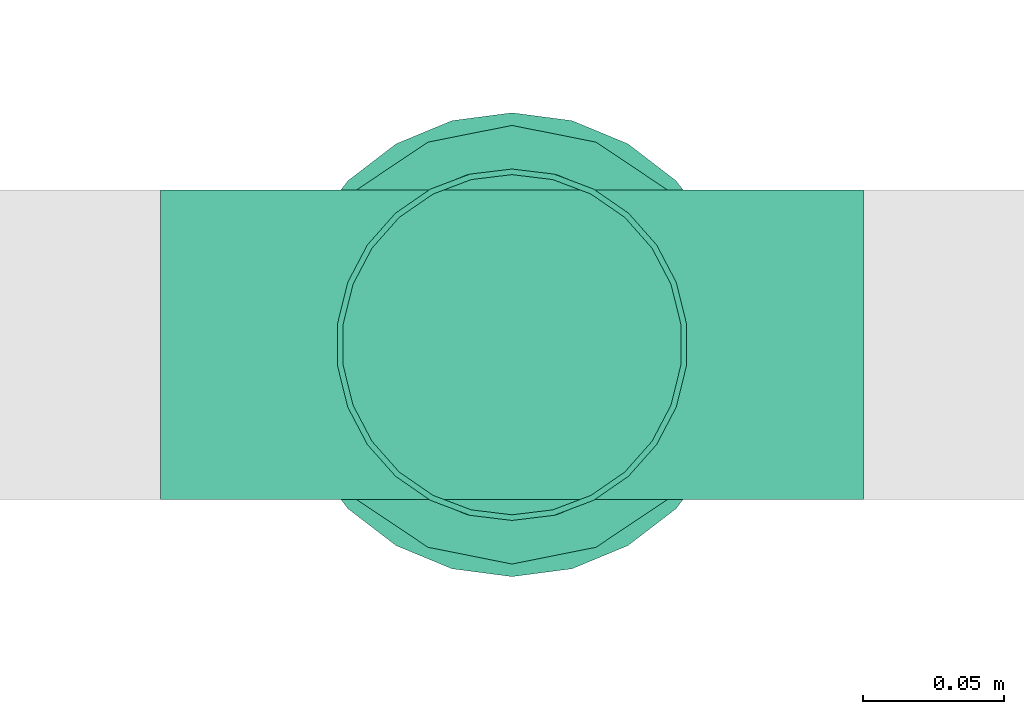
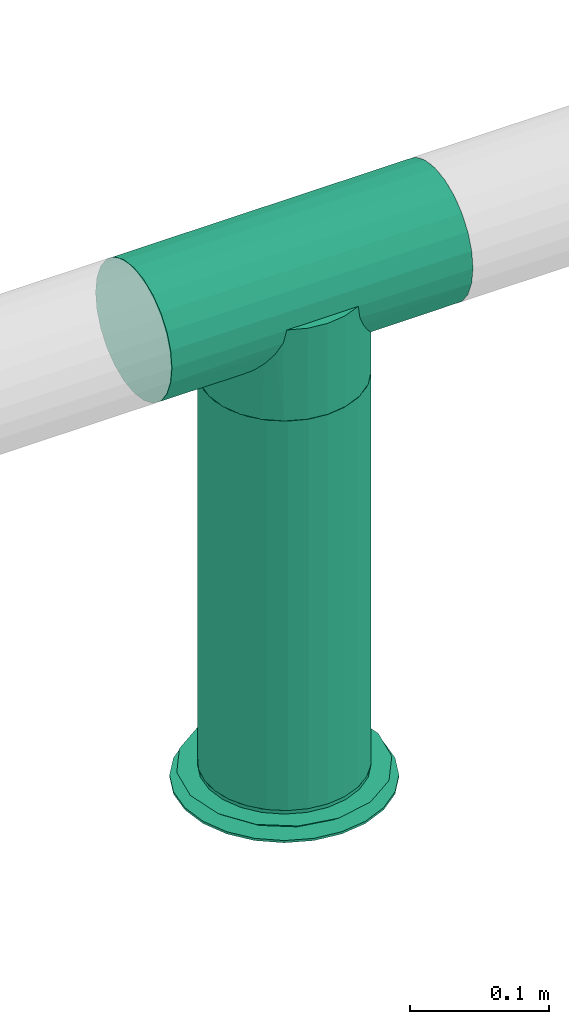
# One storey, part 83 of 123: 1 flow fitting, 1 flow segment, 1 flow terminal.
"""IFC2X3 building model written with IfcOpenShell, lengths in millimetres."""

from ifc_helpers import new_model, entity, si_unit, converted_unit, derived_unit, direction, frame, origin_with_axes, origin_2d_with_axis, place, context, subcontext, project, spatial, hollow_circle, extrude, open_shell, surface_model, source, transform, mapped, material, layer, layer_set, layer_usage, type_object, element, save


model = new_model("IFC2X3")

# Units and contexts
model_context = context("Model", 3, precision=1e-05, world=origin_with_axes(), true_north=direction((0.0, 1.0)))
body_context = subcontext(model_context, "Body", "Model", "MODEL_VIEW")
ifc_project = project(units=[si_unit("AREAUNIT", "SQUARE_METRE"), si_unit("VOLUMEUNIT", "CUBIC_METRE", prefix="DECI"), si_unit("TIMEUNIT", "SECOND"), si_unit("THERMODYNAMICTEMPERATUREUNIT", "DEGREE_CELSIUS"), si_unit("PRESSUREUNIT", "PASCAL"), si_unit("MASSUNIT", "GRAM", prefix="KILO"), si_unit("LENGTHUNIT", "METRE", prefix="MILLI"), si_unit("POWERUNIT", "WATT"), si_unit("ELECTRICCURRENTUNIT", "AMPERE"), si_unit("ELECTRICVOLTAGEUNIT", "VOLT"), derived_unit("VOLUMETRICFLOWRATEUNIT", [(si_unit("VOLUMEUNIT", "CUBIC_METRE", prefix="DECI"), 1), (si_unit("TIMEUNIT", "SECOND"), -1)]), derived_unit("LINEARVELOCITYUNIT", [(si_unit("LENGTHUNIT", "METRE"), 1), (si_unit("TIMEUNIT", "SECOND"), -1)]), derived_unit("MASSDENSITYUNIT", [(si_unit("MASSUNIT", "GRAM", prefix="KILO"), 1), (si_unit("VOLUMEUNIT", "CUBIC_METRE"), -1)]), converted_unit("PLANEANGLEUNIT", "DEGREE", entity("IfcRatioMeasure", 0.01745), si_unit("PLANEANGLEUNIT", "RADIAN"), dimensions=[0, 0, 0, 0, 0, 0, 0])], contexts=[model_context])

# Site, building, storey
site_placement = place(None, origin_with_axes())
site = spatial("IfcSite", under=ifc_project, at=site_placement, CompositionType="ELEMENT")
building_placement = place(site_placement, origin_with_axes())
building = spatial("IfcBuilding", under=site, at=building_placement, Name="mc-building", CompositionType="ELEMENT")
storey_placement = place(building_placement, origin_with_axes())
storey = spatial("IfcBuildingStorey", under=building, at=storey_placement, Name="1. Korrus", CompositionType="ELEMENT", Elevation=0.0)

# Flow terminal
air_terminal_type = type_object("IfcAirTerminalType", Name="125", PredefinedType="NOTDEFINED")
shared_shape_1 = source(origin_with_axes(), body_context, "Body", "SurfaceModel", [
    surface_model("IfcShellBasedSurfaceModel", [(11.2, 41.25, -71.4471), (11.2, 0.0, -82.5), (11.2, 21.35257, -79.68888), (11.2, 71.4471, -41.25), (11.2, 58.33631, -58.33631), (11.2, 79.68888, -21.35257), (11.2, 82.5, 0.0), (11.2, -79.68888, -21.35257), (11.2, -41.25, -71.4471), (11.2, -21.35257, -79.68888), (11.2, -58.33631, -58.33631), (11.2, -71.4471, -41.25), (11.2, 79.68888, 21.35257), (11.2, 71.4471, 41.25), (11.2, 58.33631, 58.33631), (11.2, 41.25, 71.4471), (11.2, 21.35257, 79.68888), (11.2, -58.33631, 58.33631), (11.2, -21.35257, 79.68888), (11.2, 0.0, 82.5), (11.2, -79.68888, 21.35257), (11.2, -71.4471, 41.25), (11.2, -82.5, 0.0), (11.2, -41.25, 71.4471), (9.2, 21.35257, 79.68888), (9.2, -21.35257, 79.68888), (9.2, 0.0, 82.5), (9.2, 58.33631, 58.33631), (9.2, 41.25, 71.4471), (9.2, 71.4471, 41.25), (9.2, 79.68888, 21.35257), (9.2, -58.33631, 58.33631), (9.2, -41.25, 71.4471), (9.2, -79.68888, 21.35257), (9.2, -71.4471, 41.25), (9.2, -58.33631, -58.33631), (9.2, -82.5, 0.0), (9.2, 79.68888, -21.35257), (9.2, 41.25, -71.4471), (9.2, 71.4471, -41.25), (9.2, -41.25, -71.4471), (9.2, 58.33631, -58.33631), (9.2, 0.0, -82.5), (9.2, 21.35257, -79.68888), (9.2, -71.4471, -41.25), (9.2, -79.68888, -21.35257), (9.2, -21.35257, -79.68888), (9.2, 82.5, 0.0), (9.2, 19.5, 33.77499), (9.2, 0.0, 39.0), (9.2, -19.5, 33.77499), (9.2, -39.0, 0.0), (9.2, 33.77499, 19.5), (9.2, 39.0, 0.0), (9.2, -33.77499, 19.5), (9.2, 0.0, -39.0), (9.2, -33.77499, -19.5), (9.2, -19.5, -33.77499), (9.2, 33.77499, -19.5), (9.2, 19.5, -33.77499), (6.2, 25.24133, 18.3389), (6.2, 31.2, 0.0), (6.2, 9.64133, 29.67296), (6.2, -25.24133, 18.3389), (6.2, -9.64133, 29.67296), (6.2, -31.2, 0.0), (6.2, 25.24133, -18.3389), (6.2, 9.64133, -29.67296), (6.2, -9.64133, -29.67296), (6.2, -25.24133, -18.3389), (9.2, 37.1621, -6.85914), (6.2, 28.22067, -9.16945), (9.2, 35.3242, -13.71829), (6.2, -17.44133, -24.00593), (9.2, -26.6375, -26.6375), (6.2, -28.22067, -9.16945), (9.2, -37.1621, -6.85914), (6.2, 17.44133, -24.00593), (9.2, 9.75, -36.3875), (6.2, 0.0, -29.67296), (9.2, -35.3242, -13.71829), (9.2, 26.6375, -26.6375), (9.2, -9.75, -36.3875), (9.2, -37.1621, 6.85914), (6.2, -28.22067, 9.16945), (9.2, -35.3242, 13.71829), (6.2, 17.44133, 24.00593), (9.2, 26.6375, 26.6375), (6.2, 28.22067, 9.16945), (9.2, 37.1621, 6.85914), (6.2, -17.44133, 24.00593), (9.2, -9.75, 36.3875), (6.2, 0.0, 29.67296), (9.2, 35.3242, 13.71829), (9.2, -26.6375, 26.6375), (9.2, 9.75, 36.3875), (6.2, -26.86438, 64.85634), (6.2, -49.63889, 49.63889), (6.2, -64.85634, 26.86438), (6.2, -70.2, 0.0), (6.2, 64.85634, 26.86438), (6.2, 0.0, 70.2), (6.2, 26.86438, 64.85634), (6.2, 49.63889, 49.63889), (6.2, 70.2, 0.0), (6.2, -64.85634, -26.86438), (6.2, -49.63889, -49.63889), (6.2, -26.86438, -64.85634), (6.2, 26.86438, -64.85634), (6.2, 0.0, -70.2), (6.2, 64.85634, -26.86438), (6.2, 49.63889, -49.63889), (0.0, -29.84931, 72.0626), (0.0, 0.0, 78.0), (0.0, 29.84931, 72.0626), (0.0, 55.15433, 55.15433), (0.0, 78.0, 0.0), (0.0, -55.15433, 55.15433), (0.0, -72.0626, 29.84931), (0.0, -78.0, 0.0), (0.0, 72.0626, 29.84931), (0.0, -72.0626, -29.84931), (0.0, 72.0626, -29.84931), (0.0, 55.15433, -55.15433), (0.0, 29.84931, -72.0626), (0.0, -55.15433, -55.15433), (0.0, -29.84931, -72.0626), (0.0, 0.0, -78.0), (6.2, 66.75025, -17.34304), (0.0, 63.60847, -42.50182), (6.2, 57.24762, -38.25164), (0.0, -14.92465, -75.0313), (6.2, -13.43219, -67.52817), (0.0, 42.50182, -63.60847), (6.2, 38.25164, -57.24762), (0.0, 75.0313, -14.92465), (0.0, 14.92465, -75.0313), (6.2, 13.43219, -67.52817), (0.0, -74.16695, -19.27005), (6.2, -67.52817, -13.43219), (0.0, -42.50182, -63.60847), (6.2, -38.25164, -57.24762), (0.0, -63.60847, -42.50182), (6.2, -57.24762, -38.25164), (6.2, -66.75025, 17.34304), (0.0, -63.60847, 42.50182), (6.2, -57.24762, 38.25164), (0.0, 14.92465, 75.0313), (6.2, 13.43219, 67.52817), (0.0, -42.50182, 63.60847), (6.2, -38.25164, 57.24762), (0.0, -75.0313, 14.92465), (0.0, -14.92465, 75.0313), (6.2, -13.43219, 67.52817), (0.0, 74.16695, 19.27005), (6.2, 67.52817, 13.43219), (0.0, 42.50182, 63.60847), (6.2, 38.25164, 57.24762), (0.0, 63.60847, 42.50182), (6.2, 57.24762, 38.25164), (-3.1, 16.17619, 60.37037), (-3.1, -31.25, 54.12659), (-3.1, 0.0, 62.5), (-3.1, 54.12659, 31.25), (-3.1, 31.25, 54.12659), (-3.1, 44.19417, 44.19417), (-3.1, -54.12659, -31.25), (-3.1, -54.12659, 31.25), (-3.1, -44.19417, 44.19417), (-3.1, -16.17619, 60.37037), (-3.1, -62.5, 0.0), (-3.1, -60.37037, 16.17619), (-3.1, 60.37037, 16.17619), (-3.1, 62.5, 0.0), (-3.1, 60.37037, -16.17619), (-3.1, 54.12659, -31.25), (-3.1, 44.19417, -44.19417), (-3.1, 31.25, -54.12659), (-3.1, 16.17619, -60.37037), (-3.1, -31.25, -54.12659), (-3.1, -44.19417, -44.19417), (-3.1, -60.37037, -16.17619), (-3.1, 0.0, -62.5), (-3.1, -16.17619, -60.37037), (0.0, 31.25, -54.12659), (0.0, -54.12659, -31.25), (0.0, 16.17619, -60.37037), (0.0, 54.12659, -31.25), (0.0, 44.19417, -44.19417), (0.0, 60.37037, -16.17619), (0.0, 62.5, 0.0), (0.0, 54.12659, 31.25), (0.0, 16.17619, 60.37037), (0.0, 0.0, -62.5), (0.0, -31.25, -54.12659), (0.0, -16.17619, -60.37037), (0.0, -44.19417, -44.19417), (0.0, -62.5, 0.0), (0.0, -60.37037, -16.17619), (0.0, 44.19417, 44.19417), (0.0, -54.12659, 31.25), (0.0, 31.25, 54.12659), (0.0, 0.0, 62.5), (0.0, -60.37037, 16.17619), (0.0, -31.25, 54.12659), (0.0, -44.19417, 44.19417), (0.0, -16.17619, 60.37037), (0.0, 60.37037, 16.17619), (-43.1, -14.75269, 55.05777), (-43.1, 0.0, 57.0), (-43.1, 14.75269, 55.05777), (-43.1, 28.5, 49.36345), (-43.1, 40.30508, 40.30508), (-43.1, 49.36345, 28.5), (-43.1, 55.05777, 14.75269), (-43.1, -28.5, 49.36345), (-43.1, -49.36345, 28.5), (-43.1, -40.30508, 40.30508), (-43.1, -57.0, 0.0), (-43.1, -55.05777, 14.75269), (-43.1, -40.30508, -40.30508), (-43.1, 57.0, 0.0), (-43.1, 55.05777, -14.75269), (-43.1, 28.5, -49.36345), (-43.1, 49.36345, -28.5), (-43.1, 14.75269, -55.05777), (-43.1, 40.30508, -40.30508), (-43.1, -49.36345, -28.5), (-43.1, -55.05777, -14.75269), (-43.1, -28.5, -49.36345), (-43.1, 0.0, -57.0), (-43.1, -14.75269, -55.05777), (-3.1, 57.0, 0.0), (-3.1, 14.75269, -55.05777), (-3.1, 28.5, -49.36345), (-3.1, 55.05777, -14.75269), (-3.1, 40.30508, -40.30508), (-3.1, 49.36345, -28.5), (-3.1, 55.05777, 14.75269), (-3.1, -28.5, -49.36345), (-3.1, 0.0, -57.0), (-3.1, -14.75269, -55.05777), (-3.1, -49.36345, -28.5), (-3.1, -57.0, 0.0), (-3.1, -55.05777, -14.75269), (-3.1, -40.30508, -40.30508), (-3.1, -49.36345, 28.5), (-3.1, 49.36345, 28.5), (-3.1, 40.30508, 40.30508), (-3.1, 0.0, 57.0), (-3.1, 28.5, 49.36345), (-3.1, 14.75269, 55.05777), (-3.1, -14.75269, 55.05777), (-3.1, -55.05777, 14.75269), (-3.1, -28.5, 49.36345), (-3.1, -40.30508, 40.30508)], [open_shell([[[0, 1, 2]], [[3, 0, 4]], [[5, 6, 0]], [[5, 0, 3]], [[7, 0, 6]], [[1, 8, 9]], [[1, 0, 8]], [[10, 7, 11]], [[10, 8, 0]], [[7, 10, 0]], [[6, 12, 7]], [[12, 13, 14]], [[12, 14, 15]], [[12, 16, 17]], [[16, 12, 15]], [[18, 16, 19]], [[20, 17, 21]], [[22, 7, 20]], [[17, 18, 23]], [[20, 12, 17]], [[16, 18, 17]], [[20, 7, 12]], [[24, 25, 26]], [[27, 24, 28]], [[27, 29, 30]], [[27, 30, 24]], [[31, 24, 30]], [[25, 31, 32]], [[25, 24, 31]], [[31, 33, 34]], [[31, 30, 33]], [[35, 36, 33]], [[33, 30, 37]], [[33, 37, 35]], [[38, 37, 39]], [[40, 37, 38]], [[38, 39, 41]], [[42, 38, 43]], [[36, 44, 45]], [[35, 44, 36]], [[40, 42, 46]], [[35, 37, 40]], [[38, 42, 40]], [[37, 30, 47]], [[45, 7, 36]], [[44, 11, 45]], [[8, 35, 40]], [[44, 35, 10]], [[9, 40, 46]], [[45, 11, 7]], [[7, 22, 36]], [[9, 8, 40]], [[10, 35, 8]], [[10, 11, 44]], [[1, 9, 46]], [[46, 42, 1]], [[43, 2, 42]], [[38, 0, 43]], [[3, 41, 39]], [[38, 41, 4]], [[5, 39, 37]], [[38, 4, 0]], [[0, 2, 43]], [[6, 5, 37]], [[3, 39, 5]], [[3, 4, 41]], [[47, 6, 37]], [[42, 2, 1]], [[30, 12, 47]], [[29, 13, 30]], [[15, 27, 28]], [[29, 27, 14]], [[16, 28, 24]], [[30, 13, 12]], [[12, 6, 47]], [[16, 15, 28]], [[14, 27, 15]], [[14, 13, 29]], [[19, 16, 24]], [[24, 26, 19]], [[25, 18, 26]], [[32, 23, 25]], [[21, 31, 34]], [[32, 31, 17]], [[20, 34, 33]], [[32, 17, 23]], [[23, 18, 25]], [[36, 22, 20]], [[21, 34, 20]], [[21, 17, 31]], [[33, 36, 20]], [[26, 18, 19]], [[48, 49, 50]], [[50, 51, 52]], [[50, 52, 48]], [[53, 52, 51]], [[50, 54, 51]], [[55, 51, 56]], [[55, 56, 57]], [[58, 55, 59]], [[58, 53, 55]], [[55, 53, 51]], [[60, 61, 62]], [[62, 63, 64]], [[65, 63, 62]], [[62, 61, 65]], [[66, 67, 68]], [[65, 68, 69]], [[65, 61, 68]], [[68, 61, 66]], [[61, 70, 71]], [[58, 71, 72]], [[73, 74, 69]], [[56, 75, 69]], [[76, 51, 65]], [[59, 67, 77]], [[73, 68, 57]], [[74, 73, 57]], [[67, 78, 79]], [[70, 61, 53]], [[65, 75, 76]], [[56, 80, 75]], [[66, 81, 77]], [[82, 57, 68]], [[67, 59, 78]], [[59, 77, 81]], [[81, 66, 58]], [[71, 58, 66]], [[82, 79, 55]], [[78, 55, 79]], [[68, 79, 82]], [[75, 80, 76]], [[56, 69, 74]], [[70, 72, 71]], [[65, 83, 84]], [[54, 84, 85]], [[86, 87, 60]], [[52, 88, 60]], [[89, 53, 61]], [[50, 64, 90]], [[86, 62, 48]], [[87, 86, 48]], [[64, 91, 92]], [[83, 65, 51]], [[61, 88, 89]], [[52, 93, 88]], [[63, 94, 90]], [[95, 48, 62]], [[64, 50, 91]], [[50, 90, 94]], [[94, 63, 54]], [[84, 54, 63]], [[95, 92, 49]], [[91, 49, 92]], [[62, 92, 95]], [[88, 93, 89]], [[52, 60, 87]], [[83, 85, 84]], [[96, 97, 98]], [[98, 99, 96]], [[96, 99, 100]], [[101, 96, 102]], [[100, 103, 102]], [[96, 100, 102]], [[99, 104, 100]], [[105, 106, 107]], [[105, 107, 108]], [[108, 107, 109]], [[110, 104, 111]], [[108, 111, 104]], [[99, 108, 104]], [[108, 99, 105]], [[112, 113, 114]], [[112, 114, 115]], [[116, 112, 115]], [[117, 112, 118]], [[119, 118, 112]], [[119, 112, 116]], [[116, 115, 120]], [[121, 116, 122]], [[123, 124, 122]], [[121, 122, 124]], [[125, 121, 126]], [[126, 121, 124]], [[124, 127, 126]], [[116, 121, 119]], [[110, 122, 128]], [[111, 129, 130]], [[107, 131, 132]], [[108, 133, 134]], [[104, 128, 135]], [[116, 104, 135]], [[111, 134, 123]], [[130, 122, 110]], [[136, 124, 137]], [[128, 122, 135]], [[127, 136, 109]], [[111, 123, 129]], [[119, 138, 139]], [[138, 105, 139]], [[140, 141, 106]], [[124, 108, 137]], [[139, 99, 119]], [[108, 124, 133]], [[106, 125, 140]], [[142, 143, 105]], [[123, 134, 133]], [[131, 127, 132]], [[106, 143, 125]], [[141, 126, 107]], [[126, 141, 140]], [[109, 136, 137]], [[138, 121, 105]], [[122, 130, 129]], [[125, 143, 142]], [[107, 126, 131]], [[127, 109, 132]], [[105, 121, 142]], [[98, 118, 144]], [[97, 145, 146]], [[102, 147, 148]], [[96, 149, 150]], [[99, 144, 151]], [[119, 99, 151]], [[97, 150, 117]], [[146, 118, 98]], [[152, 112, 153]], [[144, 118, 151]], [[113, 152, 101]], [[97, 117, 145]], [[116, 154, 155]], [[154, 100, 155]], [[156, 157, 103]], [[112, 96, 153]], [[155, 104, 116]], [[96, 112, 149]], [[103, 115, 156]], [[158, 159, 100]], [[117, 150, 149]], [[147, 113, 148]], [[103, 159, 115]], [[157, 114, 102]], [[114, 157, 156]], [[101, 152, 153]], [[154, 120, 100]], [[118, 146, 145]], [[115, 159, 158]], [[102, 114, 147]], [[113, 101, 148]], [[100, 120, 158]], [[160, 161, 162]], [[163, 160, 164]], [[161, 160, 163]], [[163, 164, 165]], [[163, 166, 167]], [[161, 167, 168]], [[161, 169, 162]], [[167, 170, 171]], [[167, 161, 163]], [[166, 170, 167]], [[163, 172, 173]], [[173, 174, 175]], [[173, 175, 176]], [[177, 178, 173]], [[177, 173, 176]], [[173, 178, 179]], [[166, 179, 180]], [[181, 170, 166]], [[179, 182, 183]], [[166, 163, 179]], [[182, 179, 178]], [[163, 173, 179]], [[184, 185, 186]], [[187, 184, 188]], [[187, 189, 190]], [[184, 187, 191]], [[192, 185, 184]], [[193, 194, 195]], [[193, 186, 194]], [[194, 185, 196]], [[186, 185, 194]], [[185, 197, 198]], [[190, 191, 187]], [[191, 192, 184]], [[192, 191, 199]], [[192, 200, 185]], [[192, 199, 201]], [[202, 200, 192]], [[197, 200, 203]], [[185, 200, 197]], [[200, 204, 205]], [[202, 204, 200]], [[202, 206, 204]], [[191, 190, 207]], [[172, 207, 173]], [[163, 191, 172]], [[201, 165, 164]], [[163, 165, 199]], [[192, 164, 160]], [[172, 191, 207]], [[207, 190, 173]], [[192, 201, 164]], [[199, 165, 201]], [[199, 191, 163]], [[202, 192, 160]], [[160, 162, 202]], [[169, 206, 162]], [[161, 204, 169]], [[200, 168, 167]], [[161, 168, 205]], [[203, 167, 171]], [[161, 205, 204]], [[204, 206, 169]], [[197, 203, 171]], [[200, 167, 203]], [[200, 205, 168]], [[170, 197, 171]], [[162, 206, 202]], [[181, 198, 170]], [[166, 185, 181]], [[194, 180, 179]], [[166, 180, 196]], [[195, 179, 183]], [[181, 185, 198]], [[198, 197, 170]], [[195, 194, 179]], [[196, 180, 194]], [[196, 185, 166]], [[193, 195, 183]], [[183, 182, 193]], [[178, 186, 182]], [[177, 184, 178]], [[187, 176, 175]], [[177, 176, 188]], [[189, 175, 174]], [[177, 188, 184]], [[184, 186, 178]], [[190, 189, 174]], [[187, 175, 189]], [[187, 188, 176]], [[173, 190, 174]], [[182, 186, 193]], [[208, 209, 210]], [[211, 208, 210]], [[212, 213, 214]], [[212, 214, 211]], [[208, 211, 214]], [[215, 216, 217]], [[216, 215, 208]], [[216, 218, 219]], [[216, 208, 214]], [[216, 220, 218]], [[216, 214, 221]], [[220, 216, 222]], [[223, 222, 224]], [[223, 225, 222]], [[223, 224, 226]], [[220, 222, 225]], [[218, 227, 228]], [[220, 227, 218]], [[229, 230, 231]], [[229, 220, 225]], [[230, 229, 225]], [[216, 221, 222]], [[232, 233, 234]], [[235, 234, 236]], [[235, 232, 234]], [[235, 236, 237]], [[238, 239, 233]], [[240, 239, 241]], [[240, 233, 239]], [[242, 243, 244]], [[245, 239, 246]], [[242, 245, 243]], [[238, 233, 232]], [[238, 247, 248]], [[238, 248, 249]], [[250, 251, 249]], [[250, 249, 248]], [[238, 249, 252]], [[243, 246, 253]], [[245, 246, 243]], [[246, 254, 255]], [[254, 246, 252]], [[238, 252, 246]], [[246, 239, 238]], [[214, 238, 221]], [[213, 247, 214]], [[250, 212, 211]], [[213, 212, 248]], [[251, 211, 210]], [[214, 247, 238]], [[238, 232, 221]], [[251, 250, 211]], [[248, 212, 250]], [[248, 247, 213]], [[249, 251, 210]], [[210, 209, 249]], [[254, 215, 217]], [[246, 216, 219]], [[217, 216, 255]], [[253, 219, 218]], [[208, 254, 252]], [[208, 215, 254]], [[252, 249, 208]], [[217, 255, 254]], [[216, 246, 255]], [[253, 246, 219]], [[218, 243, 253]], [[208, 249, 209]], [[228, 244, 218]], [[227, 242, 228]], [[239, 220, 229]], [[227, 220, 245]], [[241, 229, 231]], [[228, 242, 244]], [[244, 243, 218]], [[241, 239, 229]], [[245, 220, 239]], [[245, 242, 227]], [[240, 241, 231]], [[231, 230, 240]], [[233, 230, 225]], [[234, 225, 223]], [[237, 224, 222]], [[221, 235, 222]], [[225, 234, 233]], [[234, 223, 226]], [[234, 226, 236]], [[226, 224, 236]], [[224, 237, 236]], [[235, 237, 222]], [[221, 232, 235]], [[230, 233, 240]]])]),
])
flow_terminal_placement = place(storey_placement, frame((28929.65714, 6092.2195, 2200.0), z_axis=(1.0, 0.0, 0.0), x_axis=(0.0, 0.0, -1.0)))
element("IfcFlowTerminal", 1, at=flow_terminal_placement, inside=storey, type_object=air_terminal_type, Name="125", context=body_context, shape_type="MappedRepresentation", body=[
    mapped(shared_shape_1, transform((0.0, 0.0, 0.0), scale=1.0)),
])

# Flow segment
ifc_material = material(Name="FZ1")
ifc_layer = layer(ifc_material, 0.0)
ifc_layer_set = layer_set([ifc_layer], Name="FZ1")
ifc_layer_usage = layer_usage(ifc_layer_set, "AXIS1", "POSITIVE", 0.0)
duct_segment_type = type_object("IfcDuctSegmentType", PredefinedType="RIGIDSEGMENT")
shared_shape_2 = source(origin_with_axes(), body_context, "Body", "SweptSolid", [
    extrude(hollow_circle(Radius=62.5, WallThickness=2.0, at=origin_2d_with_axis()), frame((0.0, 0.0, 0.0), z_axis=(1.0, 0.0, 0.0), x_axis=(0.0, 1.0, 0.0)), (0.0, 0.0, 1.0), 341.9),
])
flow_segment_placement = place(storey_placement, frame((28929.65714, 6092.2195, 2545.0), z_axis=(-1.0, 0.0, 0.0), x_axis=(0.0, 0.0, -1.0)))
element("IfcFlowSegment", 2, at=flow_segment_placement, inside=storey, type_object=duct_segment_type, material=ifc_layer_usage, context=body_context, shape_type="MappedRepresentation", body=[
    mapped(shared_shape_2, transform((0.0, 0.0, 0.0), scale=1.0)),
])

# Flow fitting
duct_fitting_type = type_object("IfcDuctFittingType", PredefinedType="JUNCTION")
shared_shape_3 = source(origin_with_axes(), body_context, "Body", "SurfaceModel", [
    surface_model("IfcShellBasedSurfaceModel", [(0.0, -80.0, -62.5), (16.17619, -80.0, -60.37037), (-16.17619, -80.0, -60.37037), (-60.37037, -80.0, 16.17619), (-31.25, -80.0, -54.12659), (-44.19417, -80.0, -44.19417), (-54.12659, -80.0, -31.25), (62.5, -80.0, 0.0), (60.37037, -80.0, 16.17619), (44.19417, -80.0, -44.19417), (31.25, -80.0, -54.12659), (60.37037, -80.0, -16.17619), (54.12659, -80.0, -31.25), (-60.37037, -80.0, -16.17619), (-54.12659, -80.0, 31.25), (-44.19417, -80.0, 44.19417), (-31.25, -80.0, 54.12659), (-16.17619, -80.0, 60.37037), (16.17619, -80.0, 60.37037), (54.12659, -80.0, 31.25), (44.19417, -80.0, 44.19417), (31.25, -80.0, 54.12659), (0.0, -80.0, 62.5), (-62.5, -80.0, 0.0), (0.0, 0.0, 62.5), (-15.31424, 0.0, 60.59475), (-29.68586, 0.0, 55.0), (-31.79332, -11.38268, 53.80924), (-62.5, -55.0, 0.0), (-61.43518, -80.0, 8.0881), (-61.42389, -53.77401, 11.548), (-36.65815, -21.50744, 50.62045), (-42.49909, -30.41254, 45.8266), (-48.42243, -38.25549, 39.51605), (-53.88367, -44.96887, 31.66703), (-58.39386, -50.28512, 22.28019), (-61.42389, -53.77401, -11.548), (-58.39386, -50.28512, -22.28019), (-53.88367, -44.96887, -31.66703), (-48.42243, -38.25549, -39.51605), (-61.43518, -80.0, -8.0881), (-42.49909, -30.41254, -45.8266), (-31.79332, -11.38268, -53.80924), (-29.68586, 0.0, -55.0), (-15.31424, 0.0, -60.59475), (0.0, 0.0, -62.5), (-36.65815, -21.50744, -50.62045), (15.31424, 0.0, -60.59475), (29.68586, 0.0, -55.0), (31.79332, -11.38268, -53.80924), (62.5, -55.0, 0.0), (61.43518, -80.0, -8.0881), (61.42389, -53.77401, -11.548), (36.65815, -21.50744, -50.62045), (42.49909, -30.41254, -45.8266), (48.42243, -38.25549, -39.51605), (53.88367, -44.96887, -31.66703), (58.39386, -50.28512, -22.28019), (61.42389, -53.77401, 11.548), (58.39386, -50.28512, 22.28019), (53.88367, -44.96887, 31.66703), (48.42243, -38.25549, 39.51605), (61.43518, -80.0, 8.0881), (42.49909, -30.41254, 45.8266), (31.79332, -11.38268, 53.80924), (29.68586, 0.0, 55.0), (15.31424, 0.0, 60.59475), (36.65815, -21.50744, 50.62045), (-125.0, 0.0, -55.0), (-125.0, -14.23505, -53.12592), (-125.0, 14.23505, -53.12592), (-125.0, 53.12592, 14.23505), (-125.0, 27.5, -47.63139), (-125.0, 47.63139, -27.5), (-125.0, 38.89087, -38.89087), (-125.0, -55.0, 0.0), (-125.0, -53.12592, 14.23505), (-125.0, -38.89087, -38.89087), (-125.0, -27.5, -47.63139), (-125.0, -53.12592, -14.23505), (-125.0, -47.63139, -27.5), (-125.0, 53.12592, -14.23505), (-125.0, 47.63139, 27.5), (-125.0, 38.89087, 38.89087), (-125.0, -14.23505, 53.12592), (-125.0, 27.5, 47.63139), (-125.0, 14.23505, 53.12592), (-125.0, -47.63139, 27.5), (-125.0, -38.89087, 38.89087), (-125.0, -27.5, 47.63139), (-125.0, 0.0, 55.0), (-125.0, 55.0, 0.0), (125.0, 55.0, 0.0), (125.0, 0.0, -55.0), (125.0, 14.23505, -53.12592), (125.0, 27.5, -47.63139), (125.0, 38.89087, -38.89087), (125.0, 47.63139, -27.5), (125.0, -38.89087, -38.89087), (125.0, -53.12592, 14.23505), (125.0, -27.5, -47.63139), (125.0, -14.23505, -53.12592), (125.0, -47.63139, -27.5), (125.0, -53.12592, -14.23505), (125.0, -55.0, 0.0), (125.0, 53.12592, -14.23505), (125.0, 53.12592, 14.23505), (125.0, 47.63139, 27.5), (125.0, 38.89087, 38.89087), (125.0, 0.0, 55.0), (125.0, 27.5, 47.63139), (125.0, 14.23505, 53.12592), (125.0, -47.63139, 27.5), (125.0, -38.89087, 38.89087), (125.0, -27.5, 47.63139), (125.0, -14.23505, 53.12592)], [open_shell([[[0, 1, 2]], [[2, 3, 4]], [[5, 3, 6]], [[4, 3, 5]], [[2, 7, 8]], [[9, 7, 10]], [[1, 10, 7]], [[11, 7, 12]], [[9, 12, 7]], [[7, 2, 1]], [[13, 6, 3]], [[2, 14, 3]], [[2, 15, 14]], [[16, 2, 17]], [[16, 15, 2]], [[17, 2, 18]], [[19, 20, 2]], [[19, 2, 8]], [[20, 21, 2]], [[2, 21, 18]], [[18, 22, 17]], [[23, 13, 3]], [[22, 24, 25]], [[26, 27, 25]], [[28, 29, 30]], [[17, 25, 27]], [[22, 25, 17]], [[16, 31, 32]], [[16, 17, 27]], [[16, 32, 15]], [[31, 16, 27]], [[33, 34, 14]], [[35, 30, 3]], [[34, 35, 14]], [[15, 33, 14]], [[30, 29, 3]], [[3, 14, 35]], [[29, 28, 23]], [[33, 15, 32]], [[36, 37, 13]], [[38, 39, 6]], [[37, 38, 6]], [[36, 40, 28]], [[28, 40, 23]], [[13, 37, 6]], [[39, 5, 6]], [[39, 41, 5]], [[42, 43, 44]], [[36, 13, 40]], [[42, 44, 2]], [[0, 44, 45]], [[41, 46, 4]], [[42, 4, 46]], [[42, 2, 4]], [[44, 0, 2]], [[41, 4, 5]], [[0, 45, 47]], [[48, 49, 47]], [[50, 51, 52]], [[1, 47, 49]], [[0, 47, 1]], [[10, 53, 54]], [[10, 1, 49]], [[10, 54, 9]], [[53, 10, 49]], [[55, 56, 12]], [[57, 52, 11]], [[56, 57, 12]], [[9, 55, 12]], [[52, 51, 11]], [[11, 12, 57]], [[51, 50, 7]], [[55, 9, 54]], [[58, 59, 8]], [[60, 61, 19]], [[59, 60, 19]], [[58, 62, 50]], [[7, 50, 62]], [[59, 19, 8]], [[61, 20, 19]], [[61, 63, 20]], [[64, 65, 66]], [[58, 8, 62]], [[64, 66, 18]], [[22, 66, 24]], [[63, 67, 21]], [[64, 21, 67]], [[64, 18, 21]], [[66, 22, 18]], [[63, 21, 20]], [[68, 69, 70]], [[70, 71, 72]], [[73, 74, 71]], [[72, 71, 74]], [[70, 75, 76]], [[77, 75, 78]], [[69, 78, 75]], [[79, 75, 80]], [[77, 80, 75]], [[75, 70, 69]], [[73, 71, 81]], [[70, 82, 71]], [[70, 83, 82]], [[70, 84, 85]], [[85, 83, 70]], [[84, 86, 85]], [[70, 87, 88]], [[87, 70, 76]], [[88, 89, 70]], [[70, 89, 84]], [[84, 90, 86]], [[91, 81, 71]], [[92, 93, 94]], [[95, 92, 94]], [[92, 96, 97]], [[96, 92, 95]], [[98, 93, 99]], [[93, 98, 100]], [[100, 101, 93]], [[98, 99, 102]], [[102, 99, 103]], [[104, 103, 99]], [[105, 92, 97]], [[106, 107, 93]], [[93, 107, 108]], [[109, 93, 110]], [[93, 108, 110]], [[109, 110, 111]], [[112, 99, 93]], [[113, 112, 93]], [[114, 113, 93]], [[115, 114, 93]], [[115, 93, 109]], [[92, 106, 93]], [[65, 109, 111]], [[65, 111, 86]], [[85, 111, 110]], [[90, 26, 86]], [[86, 26, 65]], [[111, 85, 86]], [[110, 83, 85]], [[82, 108, 107]], [[71, 107, 106]], [[91, 106, 92]], [[83, 108, 82]], [[82, 107, 71]], [[106, 91, 71]], [[108, 83, 110]], [[81, 92, 105]], [[73, 105, 97]], [[74, 97, 96]], [[91, 92, 81]], [[81, 105, 73]], [[97, 74, 73]], [[96, 72, 74]], [[70, 95, 94]], [[93, 48, 94]], [[43, 94, 48]], [[72, 95, 70]], [[43, 68, 70]], [[94, 43, 70]], [[95, 72, 96]], [[68, 43, 42]], [[69, 42, 46]], [[78, 46, 41]], [[68, 42, 69]], [[77, 41, 39]], [[78, 69, 46]], [[41, 77, 78]], [[38, 37, 80]], [[36, 28, 75]], [[37, 36, 79]], [[77, 38, 80]], [[80, 37, 79]], [[36, 75, 79]], [[38, 77, 39]], [[49, 93, 101]], [[101, 100, 53]], [[98, 54, 100]], [[98, 55, 54]], [[48, 93, 49]], [[49, 101, 53]], [[100, 54, 53]], [[56, 98, 102]], [[57, 102, 103]], [[52, 103, 104]], [[57, 56, 102]], [[50, 52, 104]], [[57, 103, 52]], [[98, 56, 55]], [[28, 30, 75]], [[35, 34, 87]], [[30, 35, 76]], [[75, 30, 76]], [[76, 35, 87]], [[34, 88, 87]], [[34, 33, 88]], [[89, 32, 31]], [[31, 27, 84]], [[26, 90, 27]], [[32, 88, 33]], [[32, 89, 88]], [[89, 31, 84]], [[27, 90, 84]], [[58, 104, 99]], [[59, 99, 112]], [[60, 112, 113]], [[58, 50, 104]], [[60, 59, 112]], [[58, 99, 59]], [[113, 61, 60]], [[61, 113, 63]], [[63, 113, 114]], [[67, 114, 115]], [[64, 115, 109]], [[63, 114, 67]], [[64, 67, 115]], [[65, 64, 109]], [[65, 26, 24]], [[65, 24, 66]], [[24, 26, 25]], [[47, 45, 48]], [[43, 48, 45]], [[43, 45, 44]]])]),
])
flow_fitting_placement = place(storey_placement, frame((28929.65714, 6092.2195, 2625.0), z_axis=(0.0, -1.0, 0.0), x_axis=(1.0, 0.0, 0.0)))
element("IfcFlowFitting", 3, at=flow_fitting_placement, inside=storey, type_object=duct_fitting_type, context=body_context, shape_type="MappedRepresentation", body=[
    mapped(shared_shape_3, transform((0.0, 0.0, 0.0), scale=1.0)),
])

save(model, "model.ifc")
